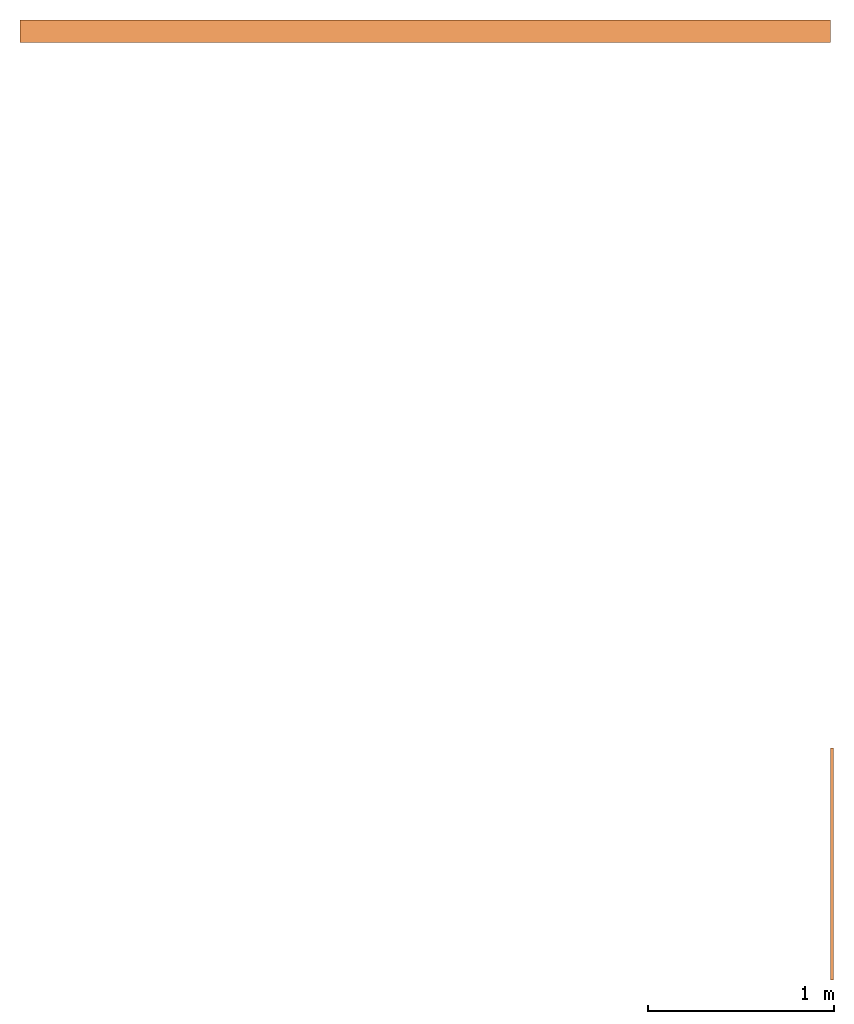
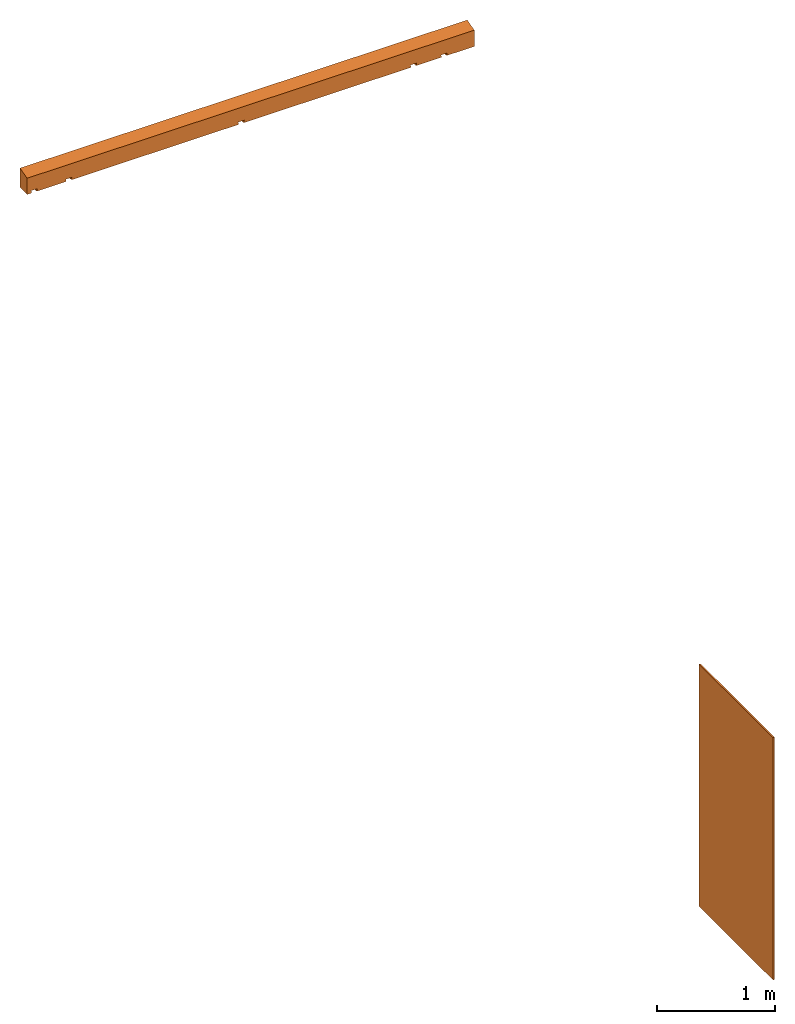
# One storey: 2 proxies.
"""IFC2X3 building model written with IfcOpenShell, lengths in millimetres."""

from ifc_helpers import new_model, entity, si_unit, converted_unit, derived_unit, origin, origin_with_axes, place, context, subcontext, project, spatial, faceted_brep, material, element, save


model = new_model("IFC2X3")

# Units and contexts
model_context = context("Model", 3, precision=0.1, world=origin())
plan_context = context("Plan", 3, precision=1e-05, world=origin_with_axes())
body_context = subcontext(model_context, "Body", "Model", "MODEL_VIEW")
ifc_project = project(units=[converted_unit("PLANEANGLEUNIT", "DEGREE", entity("IfcPositiveLengthMeasure", 0.0174532925239284), si_unit("PLANEANGLEUNIT", "RADIAN"), dimensions=[0, 0, 0, 0, 0, 0, 0]), si_unit("AREAUNIT", "SQUARE_METRE", prefix="CENTI"), si_unit("LENGTHUNIT", "METRE", prefix="MILLI"), si_unit("MASSUNIT", "GRAM", prefix="KILO"), si_unit("POWERUNIT", "WATT"), si_unit("PRESSUREUNIT", "PASCAL", prefix="KILO"), si_unit("FORCEUNIT", "NEWTON", prefix="KILO"), si_unit("ELECTRICVOLTAGEUNIT", "VOLT"), si_unit("ELECTRICCURRENTUNIT", "AMPERE"), si_unit("THERMODYNAMICTEMPERATUREUNIT", "DEGREE_CELSIUS"), si_unit("TIMEUNIT", "SECOND"), si_unit("VOLUMEUNIT", "CUBIC_METRE", prefix="CENTI"), derived_unit("LINEARVELOCITYUNIT", [(si_unit("LENGTHUNIT", "METRE"), 1), (si_unit("TIMEUNIT", "SECOND"), -1)]), derived_unit("VOLUMETRICFLOWRATEUNIT", [(si_unit("VOLUMEUNIT", "CUBIC_METRE"), 1), (si_unit("TIMEUNIT", "SECOND"), -1)]), derived_unit("THERMALTRANSMITTANCEUNIT", [(si_unit("POWERUNIT", "WATT"), 1), (si_unit("THERMODYNAMICTEMPERATUREUNIT", "KELVIN"), -1), (si_unit("AREAUNIT", "SQUARE_METRE"), -1)]), derived_unit("SOUNDPRESSUREUNIT", [(si_unit("PRESSUREUNIT", "PASCAL"), 1)])], contexts=[model_context, plan_context])

# Site, building, storey
site_placement = place(None, origin_with_axes())
site = spatial("IfcSite", under=ifc_project, at=site_placement, CompositionType="ELEMENT")
building_placement = place(site_placement, origin_with_axes())
building = spatial("IfcBuilding", under=site, at=building_placement, CompositionType="ELEMENT")
storey_placement = place(building_placement, origin_with_axes())
storey = spatial("IfcBuildingStorey", under=building, at=storey_placement, CompositionType="ELEMENT")

# Proxies
ifc_material_1 = material(Name="OSB")
proxy_1_placement = place(storey_placement, origin_with_axes())
element("IfcBuildingElementProxy", 1, at=proxy_1_placement, inside=storey, material=ifc_material_1, Name="OSB Platte", context=body_context, shape_type="Brep", body=[
    faceted_brep([(4540.0, 3790.0, 10.0), (4525.0, 3790.0, 10.0), (4525.0, 5040.0, 10.0), (4540.0, 5040.0, 10.0), (4540.0, 3790.0, 2510.0), (4540.0, 5040.0, 2510.0), (4525.0, 5040.0, 2510.0), (4525.0, 3790.0, 2510.0)], [[[0, 1, 2, 3]], [[4, 5, 6, 7]], [[0, 4, 7, 1]], [[1, 7, 6, 2]], [[2, 6, 5, 3]], [[3, 5, 4, 0]]]),
])
ifc_material_2 = material(Name="C24")
proxy_2_placement = place(storey_placement, origin_with_axes())
element("IfcBuildingElementProxy", 2, at=proxy_2_placement, inside=storey, material=ifc_material_2, context=body_context, shape_type="Brep", body=[
    faceted_brep([(160.0, 8840.0, 6580.8), (204.7, 8840.0, 6580.8), (199.8, 8840.0, 6605.8), (260.2, 8840.0, 6605.8), (255.3, 8840.0, 6580.8), (542.4, 8840.0, 6580.8), (537.5, 8840.0, 6605.8), (597.9, 8840.0, 6605.8), (593.0, 8840.0, 6580.8), (2224.7, 8840.0, 6580.8), (2219.8, 8840.0, 6605.8), (2280.2, 8840.0, 6605.8), (2275.3, 8840.0, 6580.8), (3907.0, 8840.0, 6580.8), (3902.1, 8840.0, 6605.8), (3962.5, 8840.0, 6605.8), (3957.6, 8840.0, 6580.8), (4204.7, 8840.0, 6580.8), (4199.8, 8840.0, 6605.8), (4260.2, 8840.0, 6605.8), (4255.3, 8840.0, 6580.8), (4525.0, 8840.0, 6580.8), (4525.0, 8840.0, 6748.7), (160.0, 8840.0, 6748.7), (160.0, 8960.0, 6580.8), (160.0, 8960.0, 6780.8), (1566.5, 8960.0, 6780.8), (4525.0, 8960.0, 6780.8), (4525.0, 8960.0, 6580.8), (4248.7, 8935.0, 6580.8), (4211.3, 8935.0, 6580.8), (3950.9, 8935.0, 6580.8), (3913.6, 8935.0, 6580.8), (2268.7, 8935.0, 6580.8), (2231.3, 8935.0, 6580.8), (586.4, 8935.0, 6580.8), (549.1, 8935.0, 6580.8), (248.7, 8935.0, 6580.8), (211.3, 8935.0, 6580.8), (2273.6, 8935.0, 6605.8), (2226.4, 8935.0, 6605.8), (3955.9, 8935.0, 6605.8), (3908.7, 8935.0, 6605.8), (591.3, 8935.0, 6605.8), (544.1, 8935.0, 6605.8), (253.6, 8935.0, 6605.8), (206.4, 8935.0, 6605.8), (4253.6, 8935.0, 6605.8), (4206.4, 8935.0, 6605.8)], [[[0, 1, 2, 3, 4, 5, 6, 7, 8, 9, 10, 11, 12, 13, 14, 15, 16, 17, 18, 19, 20, 21, 22, 23]], [[24, 25, 26, 27, 28]], [[21, 20, 29, 30, 17, 16, 31, 32, 13, 12, 33, 34, 9, 8, 35, 36, 5, 4, 37, 38, 1, 0, 24, 28]], [[21, 28, 27, 22]], [[26, 27]], [[0, 23, 25, 24]], [[33, 39, 40, 34]], [[10, 40, 39, 11]], [[9, 34, 40, 10]], [[11, 39, 33, 12]], [[31, 41, 42, 32]], [[14, 42, 41, 15]], [[13, 32, 42, 14]], [[15, 41, 31, 16]], [[35, 43, 44, 36]], [[6, 44, 43, 7]], [[5, 36, 44, 6]], [[7, 43, 35, 8]], [[37, 45, 46, 38]], [[2, 46, 45, 3]], [[1, 38, 46, 2]], [[3, 45, 37, 4]], [[29, 47, 48, 30]], [[18, 48, 47, 19]], [[17, 30, 48, 18]], [[19, 47, 29, 20]], [[23, 22, 27, 26, 25]]]),
])

save(model, "model.ifc")
